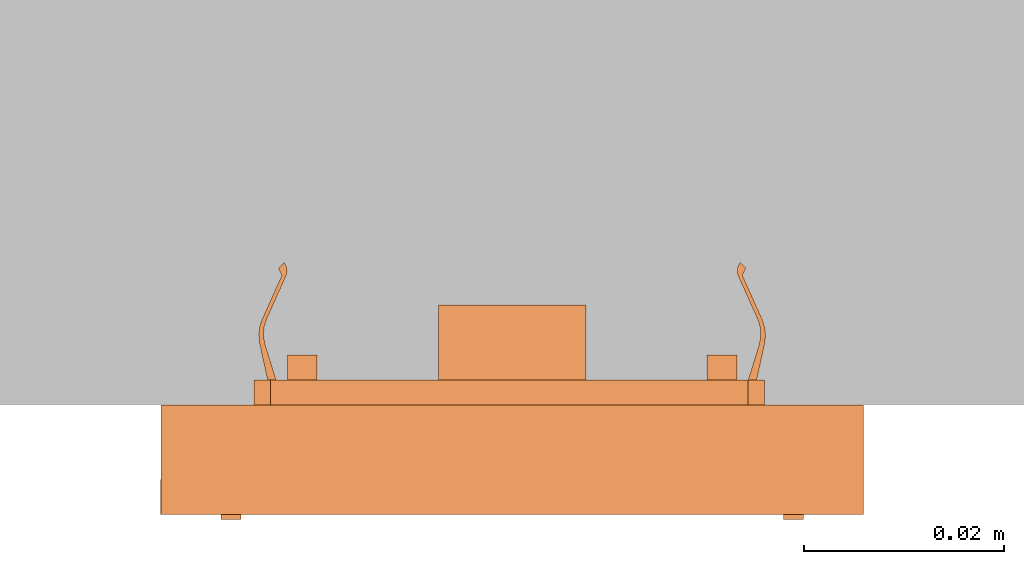
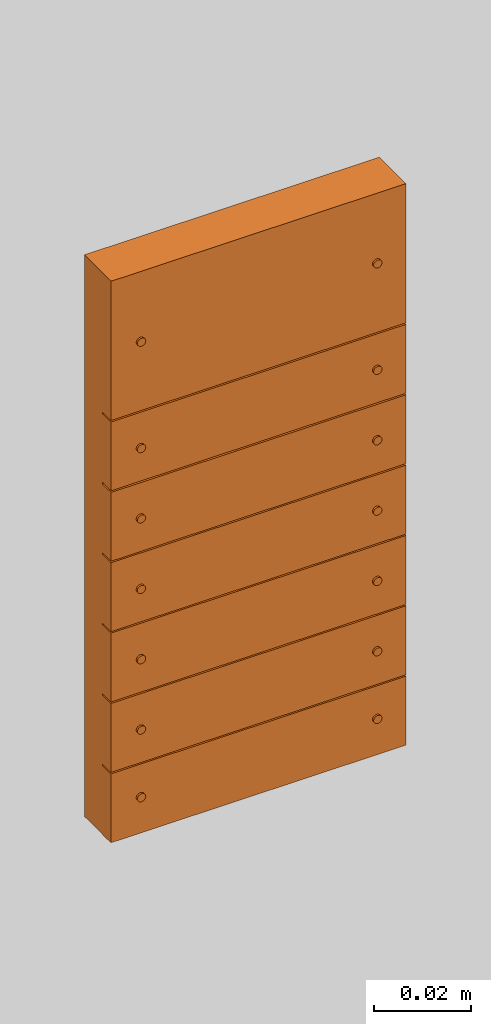
# One storey, part 2 of 2: 1 proxy.
"""IFC2X3 building model written with IfcOpenShell, lengths in metres."""

import ifcopenshell
import ifcopenshell.guid

model = None  # the IFC model being written
_history = None  # IfcOwnerHistory: only IFC2X3 demands one
_inside = {}  # id of a spatial element -> (the spatial element, [elements in it])
_under = {}  # id of a project, library or spatial element -> (it, [spatial elements below it])
_declared = {}  # id of a project -> (the project, [libraries it declares])
_typed = {}  # id of a type object -> (the type object, [elements of that type])
_made_of = {}  # id of a material, layer set ... -> (it, [elements and type objects made of it])


def new_model(schema):
    """Start an empty IFC model of exactly this schema.

    Asked for "IFC4X3", IfcOpenShell would pick the latest addendum, in which some entities
    have other attributes; the version numbers below select the first issue.
    IFC2X3 requires an IfcOwnerHistory on every rooted entity: one is made here for all.
    """
    global model, _history
    if schema == "IFC4X3":
        model = ifcopenshell.file(schema_version=(4, 3, 0, 0))
    else:
        model = ifcopenshell.file(schema=schema)
    _inside.clear()
    _under.clear()
    _declared.clear()
    _typed.clear()
    _made_of.clear()
    _history = None
    if model.schema == "IFC2X3":
        org = make("IfcOrganization", Name="unknown")
        user = make(
            "IfcPersonAndOrganization",
            ThePerson=make("IfcPerson", FamilyName="unknown"),
            TheOrganization=org,
        )
        app = make(
            "IfcApplication",
            ApplicationDeveloper=org,
            Version="unknown",
            ApplicationFullName="unknown",
            ApplicationIdentifier="unknown",
        )
        _history = make(
            "IfcOwnerHistory",
            OwningUser=user,
            OwningApplication=app,
            ChangeAction="ADDED",
            CreationDate=0,
        )
    return model


def make(cls, **values):
    """One entity of the class cls with the attributes given. An attribute that is None is left unset."""
    return model.create_entity(
        cls, **{name: value for name, value in values.items() if value is not None}
    )


def entity(cls, *values):
    """Any entity or typed value of the class cls, its attributes in the order of the schema. None: left unset."""
    e = model.create_entity(cls)
    for i, value in enumerate(values):
        if value is not None:
            e[i] = value
    return e


def rooted(cls, **values):
    """An entity with a GlobalId (a new one), such as an element, a storey or a relation."""
    return make(cls, GlobalId=ifcopenshell.guid.new(), OwnerHistory=_history, **values)


def si_unit(unit_type, name, prefix=None):
    """IfcSIUnit, for example si_unit("LENGTHUNIT", "METRE", prefix="MILLI")."""
    return make("IfcSIUnit", UnitType=unit_type, Prefix=prefix, Name=name)


def converted_unit(unit_type, name, factor, base, dimensions=None, offset=None):
    """IfcConversionBasedUnit, such as the inch: factor (a typed value) times the base unit."""
    return make(
        "IfcConversionBasedUnit"
        if offset is None
        else "IfcConversionBasedUnitWithOffset",
        ConversionOffset=offset,
        Dimensions=None
        if dimensions is None
        else entity("IfcDimensionalExponents", *dimensions),
        UnitType=unit_type,
        Name=name,
        ConversionFactor=make(
            "IfcMeasureWithUnit", ValueComponent=factor, UnitComponent=base
        ),
    )


def derived_unit(unit_type, elements):
    """IfcDerivedUnit: a product of units, each with its exponent."""
    return make(
        "IfcDerivedUnit",
        Elements=[
            make("IfcDerivedUnitElement", Unit=unit, Exponent=power)
            for unit, power in elements
        ],
        UnitType=unit_type,
    )


def assignment(units):
    """IfcUnitAssignment: the units of a project."""
    return None if units is None else make("IfcUnitAssignment", Units=units)


def point(xyz):
    """IfcCartesianPoint."""
    return None if xyz is None else make("IfcCartesianPoint", Coordinates=xyz)


def direction(xyz):
    """IfcDirection."""
    return None if xyz is None else make("IfcDirection", DirectionRatios=xyz)


def frame(location, z_axis=None, x_axis=None):
    """IfcAxis2Placement3D, a coordinate frame: its origin and axes. An axis left out is left unset."""
    return make(
        "IfcAxis2Placement3D",
        Location=point(location),
        Axis=direction(z_axis),
        RefDirection=direction(x_axis),
    )


def frame_2d(location, x_axis=None):
    """IfcAxis2Placement2D, a coordinate frame in the plane: its origin and x axis."""
    return make(
        "IfcAxis2Placement2D", Location=point(location), RefDirection=direction(x_axis)
    )


def origin():
    """The frame at (0, 0, 0) with its axes left unset."""
    return frame((0.0, 0.0, 0.0))


def origin_2d_with_axis():
    """The frame at (0, 0) in the plane with the x axis (1, 0) written out."""
    return frame_2d((0.0, 0.0), x_axis=(1.0, 0.0))


def place(relative_to, where):
    """IfcLocalPlacement: puts the frame where relative to a parent placement (None: the world)."""
    return make(
        "IfcLocalPlacement", PlacementRelTo=relative_to, RelativePlacement=where
    )


def context(
    kind, dimensions, precision=None, world=None, true_north=None, identifier=None
):
    """IfcGeometricRepresentationContext, for example the 3D "Model" context."""
    return make(
        "IfcGeometricRepresentationContext",
        ContextIdentifier=identifier,
        ContextType=kind,
        CoordinateSpaceDimension=dimensions,
        Precision=precision,
        WorldCoordinateSystem=world,
        TrueNorth=true_north,
    )


def subcontext(parent, identifier, kind, view, scale=None):
    """IfcGeometricRepresentationSubContext, for example "Body" below "Model"."""
    return make(
        "IfcGeometricRepresentationSubContext",
        ContextIdentifier=identifier,
        ContextType=kind,
        ParentContext=parent,
        TargetScale=scale,
        TargetView=view,
    )


def project(units=None, contexts=None):
    """IfcProject with its units and contexts."""
    return rooted(
        "IfcProject",
        Name="project",
        RepresentationContexts=contexts,
        UnitsInContext=assignment(units),
    )


def spatial(cls, under=None, at=None, **own):
    """A site, building, storey or space (cls), placed at a placement, below another one or the project."""
    s = rooted(cls, ObjectPlacement=at, **own)
    if under is not None:
        _under.setdefault(under.id(), (under, []))[1].append(s)
    return s


def polyline(points):
    """IfcPolyline through the points."""
    return make("IfcPolyline", Points=[point(p) for p in points])


def circle_curve(where, radius):
    """IfcCircle in the frame where."""
    return make("IfcCircle", Position=where, Radius=radius)


def parameter(value):
    """IfcParameterValue: where a trimmed curve begins or ends, as a parameter of its basis curve."""
    return model.create_entity("IfcParameterValue", value)


def trimmed(basis, trim1, trim2, sense, master):
    """IfcTrimmedCurve: the piece of a basis curve between two trims."""
    return make(
        "IfcTrimmedCurve",
        BasisCurve=basis,
        Trim1=trim1,
        Trim2=trim2,
        SenseAgreement=sense,
        MasterRepresentation=master,
    )


def segment(curve, same_sense, transition):
    """IfcCompositeCurveSegment."""
    return make(
        "IfcCompositeCurveSegment",
        Transition=transition,
        SameSense=same_sense,
        ParentCurve=curve,
    )


def composite_curve(segments, self_intersect=None):
    """IfcCompositeCurve: segments joined end to end."""
    return make("IfcCompositeCurve", Segments=segments, SelfIntersect=self_intersect)


def profile(cls, at=None, kind="AREA", **sizes):
    """A parametric profile (cls). Its sizes go by their IFC names, for example OverallWidth=200.0."""
    return make(cls, ProfileType=kind, Position=at, **sizes)


def rectangle(**sizes):
    """IfcRectangleProfileDef."""
    return profile("IfcRectangleProfileDef", **sizes)


def circle(**sizes):
    """IfcCircleProfileDef."""
    return profile("IfcCircleProfileDef", **sizes)


def outline(outer, holes=None, kind="AREA"):
    """IfcArbitraryClosedProfileDef: a profile drawn as a closed curve; with holes, ...WithVoids."""
    if holes is None:
        return make("IfcArbitraryClosedProfileDef", ProfileType=kind, OuterCurve=outer)
    return make(
        "IfcArbitraryProfileDefWithVoids",
        ProfileType=kind,
        OuterCurve=outer,
        InnerCurves=holes,
    )


def extrude(swept, where, along, depth):
    """IfcExtrudedAreaSolid: the profile swept, set in the frame where, extruded along a direction by depth."""
    return make(
        "IfcExtrudedAreaSolid",
        SweptArea=swept,
        Position=where,
        ExtrudedDirection=direction(along),
        Depth=depth,
    )


def shape(context_of_items, identifier, shape_type, items):
    """IfcShapeRepresentation: the items that make up one representation, for example the "Body"."""
    return make(
        "IfcShapeRepresentation",
        ContextOfItems=context_of_items,
        RepresentationIdentifier=identifier,
        RepresentationType=shape_type,
        Items=items,
    )


def source(mapping_origin, context_of_items, identifier, shape_type, items):
    """IfcRepresentationMap: a shape defined once, which mapped items show again and again."""
    return make(
        "IfcRepresentationMap",
        MappingOrigin=mapping_origin,
        MappedRepresentation=shape(context_of_items, identifier, shape_type, items),
    )


def transform(
    local_origin,
    x_axis=None,
    y_axis=None,
    z_axis=None,
    scale=None,
    scale2=None,
    scale3=None,
    uniform=True,
):
    """IfcCartesianTransformationOperator3D, or its non-uniform kind. x_axis, y_axis, z_axis: its Axis1, 2, 3."""
    if uniform:
        return make(
            "IfcCartesianTransformationOperator3D",
            Axis1=direction(x_axis),
            Axis2=direction(y_axis),
            LocalOrigin=point(local_origin),
            Scale=scale,
            Axis3=direction(z_axis),
        )
    return make(
        "IfcCartesianTransformationOperator3DnonUniform",
        Axis1=direction(x_axis),
        Axis2=direction(y_axis),
        LocalOrigin=point(local_origin),
        Scale=scale,
        Axis3=direction(z_axis),
        Scale2=scale2,
        Scale3=scale3,
    )


def mapped(mapping_source, mapping_target):
    """IfcMappedItem: shows the shape of a source again, moved by a transform."""
    return make(
        "IfcMappedItem", MappingSource=mapping_source, MappingTarget=mapping_target
    )


def made_of(thing, what):
    """Note that an element or type object is made of a material, layer set ...; save() writes the relation."""
    if what is not None:
        _made_of.setdefault(what.id(), (what, []))[1].append(thing)
    return thing


def type_object(cls, material=None, **own):
    """A type object (cls), such as IfcWallType, which elements share."""
    return made_of(rooted(cls, **own), material)


def type_shapes(of_type, sources):
    """Give a type object the sources (RepresentationMaps) that its elements show as mapped items."""
    of_type.RepresentationMaps = sources


def element(
    cls,
    number,
    at=None,
    inside=None,
    cuts=None,
    type_object=None,
    material=None,
    context=None,
    identifier="Body",
    shape_type=None,
    held_by="IfcProductDefinitionShape",
    body=None,
    shapes=None,
    **own,
):
    """One element of the class cls, such as IfcWall. Its Tag is "e" and its number.

    at: its placement. inside: the storey or other place that contains it. cuts: it is an
    opening in that element (IfcRelVoidsElement). A single representation is given by context,
    identifier, shape_type and body (its items); several are given by shapes. held_by: the class
    of the entity that holds the representations. save() writes the other relations.
    """
    e = rooted(cls, Tag="e%d" % number, ObjectPlacement=at, **own)
    if body is not None:
        shapes = [shape(context, identifier, shape_type, body)]
    if shapes is not None:
        e.Representation = make(held_by, Representations=shapes)
    if inside is not None:
        _inside.setdefault(inside.id(), (inside, []))[1].append(e)
    if cuts is not None:
        rooted(
            "IfcRelVoidsElement", RelatingBuildingElement=cuts, RelatedOpeningElement=e
        )
    if type_object is not None:
        _typed.setdefault(type_object.id(), (type_object, []))[1].append(e)
    return made_of(e, material)


def aggregate(whole, parts):
    """IfcRelAggregates: a whole, such as a stair, and the parts it consists of."""
    return rooted("IfcRelAggregates", RelatingObject=whole, RelatedObjects=parts)


def save(model, path):
    """Write the relations noted so far, then the file.

    IfcRelAggregates (storeys below a building ...), IfcRelContainedInSpatialStructure (elements
    in a storey), IfcRelDefinesByType, IfcRelAssociatesMaterial and IfcRelDeclares: one each for
    every whole, place, type object, material and project.
    """
    for whole, parts in _under.values():
        aggregate(whole, parts)
    for where, things in _inside.values():
        rooted(
            "IfcRelContainedInSpatialStructure",
            RelatedElements=things,
            RelatingStructure=where,
        )
    for kind, things in _typed.values():
        rooted("IfcRelDefinesByType", RelatedObjects=things, RelatingType=kind)
    for what, things in _made_of.values():
        rooted("IfcRelAssociatesMaterial", RelatedObjects=things, RelatingMaterial=what)
    for by, libraries in _declared.values():
        rooted("IfcRelDeclares", RelatingContext=by, RelatedDefinitions=libraries)
    model.write(path)


model = new_model("IFC2X3")

# Units and contexts
model_context = context("Model", 3, precision=1e-05, world=origin(), true_north=direction((6.12303176911189e-17, 1.0)))
body_context = subcontext(model_context, "Body", "Model", "MODEL_VIEW")
ifc_project = project(units=[si_unit("LENGTHUNIT", "METRE"), si_unit("AREAUNIT", "SQUARE_METRE"), si_unit("VOLUMEUNIT", "CUBIC_METRE"), converted_unit("PLANEANGLEUNIT", "DEGREE", entity("IfcRatioMeasure", 0.0174532925199433), si_unit("PLANEANGLEUNIT", "RADIAN"), dimensions=[0, 0, 0, 0, 0, 0, 0]), si_unit("MASSUNIT", "GRAM", prefix="KILO"), si_unit("TIMEUNIT", "SECOND"), si_unit("FREQUENCYUNIT", "HERTZ"), si_unit("THERMODYNAMICTEMPERATUREUNIT", "DEGREE_CELSIUS"), derived_unit("THERMALTRANSMITTANCEUNIT", [(si_unit("MASSUNIT", "GRAM", prefix="KILO"), 1), (si_unit("THERMODYNAMICTEMPERATUREUNIT", "KELVIN"), -1), (si_unit("TIMEUNIT", "SECOND"), -3)]), derived_unit("VOLUMETRICFLOWRATEUNIT", [(si_unit("LENGTHUNIT", "METRE"), 3), (si_unit("TIMEUNIT", "SECOND"), -1)]), si_unit("ELECTRICCURRENTUNIT", "AMPERE"), si_unit("ELECTRICVOLTAGEUNIT", "VOLT"), si_unit("POWERUNIT", "WATT"), si_unit("FORCEUNIT", "NEWTON", prefix="KILO"), si_unit("ILLUMINANCEUNIT", "LUX"), si_unit("LUMINOUSFLUXUNIT", "LUMEN"), si_unit("LUMINOUSINTENSITYUNIT", "CANDELA"), derived_unit("USERDEFINED", [(si_unit("MASSUNIT", "GRAM", prefix="KILO"), -1), (si_unit("LENGTHUNIT", "METRE"), -2), (si_unit("TIMEUNIT", "SECOND"), 3), (si_unit("LUMINOUSFLUXUNIT", "LUMEN"), 1)]), derived_unit("LINEARVELOCITYUNIT", [(si_unit("LENGTHUNIT", "METRE"), 1), (si_unit("TIMEUNIT", "SECOND"), -1)]), si_unit("PRESSUREUNIT", "PASCAL"), derived_unit("USERDEFINED", [(si_unit("LENGTHUNIT", "METRE"), -2), (si_unit("MASSUNIT", "GRAM", prefix="KILO"), 1), (si_unit("TIMEUNIT", "SECOND"), -2)])], contexts=[model_context])

# Site, building, storey
site_placement = place(None, origin())
site = spatial("IfcSite", under=ifc_project, at=site_placement, CompositionType="ELEMENT")
building_placement = place(site_placement, origin())
building = spatial("IfcBuilding", under=site, at=building_placement, CompositionType="ELEMENT")
storey_placement = place(building_placement, origin())
storey = spatial("IfcBuildingStorey", under=building, at=storey_placement, Name="Ebene 0", CompositionType="ELEMENT", Elevation=0.0)

# Proxy
building_element_proxy_type = type_object("IfcBuildingElementProxyType", Name="KNX 3 Plus 6f (2+4)", PredefinedType="NOTDEFINED")
shared_shape = source(origin(), body_context, "Body", "SweptSolid", [
    extrude(outline(composite_curve([segment(polyline([(0.000467124920745134, -0.0238772156111111), (0.0193443469207452, -0.0238772156111111)]), True, "CONTINUOUS"), segment(trimmed(circle_curve(frame_2d((0.0193443469207451, -0.0188772156111111), x_axis=(-1.0, 0.0)), 0.005), [parameter(90.0000000000001)], [parameter(180.0)], True, "PARAMETER"), True, "CONTINUOUS"), segment(polyline([(0.0243443469207451, -0.0188772156111111), (0.0243443469207451, -0.00697722161111111)]), True, "CONTINUOUS"), segment(polyline([(0.0243443469207451, -0.00697722161111111), (0.0259943469207451, -0.00697722161111111)]), True, "CONTINUOUS"), segment(polyline([(0.0259943469207451, -0.00697722161111111), (0.0259943469207451, 0.0069772233888889)]), True, "CONTINUOUS"), segment(polyline([(0.0259943469207451, 0.0069772233888889), (0.0243443469207451, 0.0069772233888889)]), True, "CONTINUOUS"), segment(polyline([(0.0243443469207451, 0.0069772233888889), (0.0243443469207451, 0.0188772173888889)]), True, "CONTINUOUS"), segment(trimmed(circle_curve(frame_2d((0.0193443469207451, 0.0188772173888889), x_axis=(-1.0, 0.0)), 0.005), [parameter(180.0)], [parameter(269.999999999999)], True, "PARAMETER"), True, "CONTINUOUS"), segment(polyline([(0.0193443469207451, 0.0238772173888889), (-0.00794112365266727, 0.0238772173888889)]), True, "CONTINUOUS"), segment(polyline([(-0.00794112365266727, 0.0238772173888889), (-0.0184100970792549, 0.0238772173888889)]), True, "CONTINUOUS"), segment(trimmed(circle_curve(frame_2d((-0.0184100970792549, 0.0188772173888889), x_axis=(-1.0, 0.0)), 0.005), [parameter(270.0)], [parameter(360.0)], True, "PARAMETER"), True, "CONTINUOUS"), segment(polyline([(-0.0234100970792549, 0.0188772173888889), (-0.0234100970792549, 0.0069772233888889)]), True, "CONTINUOUS"), segment(polyline([(-0.0234100970792549, 0.0069772233888889), (-0.0250600970792549, 0.0069772233888889)]), True, "CONTINUOUS"), segment(polyline([(-0.0250600970792549, 0.0069772233888889), (-0.0250600970792549, -0.00697722161111111)]), True, "CONTINUOUS"), segment(polyline([(-0.0250600970792549, -0.00697722161111111), (-0.0234100970792549, -0.00697722161111111)]), True, "CONTINUOUS"), segment(polyline([(-0.0234100970792549, -0.00697722161111111), (-0.0234100970792549, -0.0188772236111111)]), True, "CONTINUOUS"), segment(trimmed(circle_curve(frame_2d((-0.0184100970792549, -0.0188772236111111), x_axis=(-1.0, 0.0)), 0.005), [parameter(0.0)], [parameter(90.0000000000001)], True, "PARAMETER"), True, "CONTINUOUS"), segment(polyline([(-0.0184100970792548, -0.0238772236111111), (0.000467124920745136, -0.0238772236111111)]), True, "CONTINUOUS")], self_intersect=False)), frame((0.000176586434071463, -0.0709999951111364, -0.00250000000000187), z_axis=(0.0, 0.0, 1.0), x_axis=(-1.0, 0.0, 0.0)), (0.0, 0.0, 1.0), 0.0025),
    extrude(circle(Radius=0.001, at=origin_2d_with_axis()), frame((0.0281503279999938, -0.0969685375000254, 0.0109999999999981), z_axis=(0.0, 0.0, 1.0), x_axis=(-1.0, 0.0, 0.0)), (0.0, 0.0, 1.0), 0.000500000000000028),
    extrude(circle(Radius=0.001, at=origin_2d_with_axis()), frame((-0.0281503279999813, -0.0969685375000254, 0.0109999999999981)), (0.0, 0.0, 1.0), 0.000500000000000028),
    extrude(circle(Radius=0.001, at=origin_2d_with_axis()), frame((0.0281503279999938, -0.0799535355000252, 0.0109999999999981), z_axis=(0.0, 0.0, 1.0), x_axis=(-1.0, 0.0, 0.0)), (0.0, 0.0, 1.0), 0.000500000000000028),
    extrude(circle(Radius=0.001, at=origin_2d_with_axis()), frame((-0.0281503279999813, -0.0799535355000252, 0.0109999999999981)), (0.0, 0.0, 1.0), 0.000500000000000028),
    extrude(circle(Radius=0.001, at=origin_2d_with_axis()), frame((0.0281503279999938, -0.0622244115000253, 0.0109999999999981), z_axis=(0.0, 0.0, 1.0), x_axis=(-1.0, 0.0, 0.0)), (0.0, 0.0, 1.0), 0.000500000000000028),
    extrude(circle(Radius=0.001, at=origin_2d_with_axis()), frame((-0.0281503279999813, -0.0622244115000253, 0.0109999999999981)), (0.0, 0.0, 1.0), 0.000500000000000028),
    extrude(circle(Radius=0.001, at=origin_2d_with_axis()), frame((0.0281503279999938, -0.0445001955000252, 0.0109999999999981), z_axis=(0.0, 0.0, 1.0), x_axis=(-1.0, 0.0, 0.0)), (0.0, 0.0, 1.0), 0.000500000000000028),
    extrude(circle(Radius=0.001, at=origin_2d_with_axis()), frame((-0.0281503279999813, -0.0445001955000252, 0.0109999999999981)), (0.0, 0.0, 1.0), 0.000500000000000028),
    extrude(circle(Radius=0.001, at=frame_2d((0.0, -4.22994972382185e-18), x_axis=(1.0, 0.0))), frame((0.0281503279999938, -0.0267710735000253, 0.0109999999999981), z_axis=(0.0, 0.0, 1.0), x_axis=(-1.0, 0.0, 0.0)), (0.0, 0.0, 1.0), 0.000500000000000028),
    extrude(circle(Radius=0.001, at=frame_2d((0.0, -4.22994972382185e-18), x_axis=(1.0, 0.0))), frame((-0.0281503279999813, -0.0267710735000253, 0.0109999999999981)), (0.0, 0.0, 1.0), 0.000500000000000028),
    extrude(circle(Radius=0.001, at=frame_2d((0.0, -2.11497486191092e-18), x_axis=(1.0, 0.0))), frame((0.0281503279999938, -0.00902937150002529, 0.0109999999999981), z_axis=(0.0, 0.0, 1.0), x_axis=(-1.0, 0.0, 0.0)), (0.0, 0.0, 1.0), 0.000500000000000028),
    extrude(circle(Radius=0.001, at=frame_2d((0.0, -2.11497486191092e-18), x_axis=(1.0, 0.0))), frame((-0.0281503279999813, -0.00902937150002528, 0.0109999999999981)), (0.0, 0.0, 1.0), 0.000500000000000028),
    extrude(circle(Radius=0.001, at=frame_2d((0.0, -2.11497486191092e-18), x_axis=(1.0, 0.0))), frame((0.0281503279999938, 0.0177710734999747, 0.0109999999999981), z_axis=(0.0, 0.0, 1.0), x_axis=(-1.0, 0.0, 0.0)), (0.0, 0.0, 1.0), 0.000500000000000028),
    extrude(circle(Radius=0.001, at=frame_2d((0.0, -2.11497486191092e-18), x_axis=(1.0, 0.0))), frame((-0.0281503279999812, 0.0177710734999747, 0.0109999999999981)), (0.0, 0.0, 1.0), 0.000500000000000028),
    extrude(outline(polyline([(-0.00737665776090717, -0.00321845649999999), (0.00738192423909283, -0.00321845649999999), (0.00738192423909283, 0.00284013749999998), (0.00654480379664712, 0.00284013749999998), (0.00654480379664711, -0.00245988050000001), (-0.00655007027483279, -0.00245988050000001), (-0.00655007027483277, 0.00283819950000002), (-0.00737665776090717, 0.00283819950000002), (-0.00737665776090717, -0.00321845649999999)])), frame((2.6332391116218e-06, -0.0187020095000253, -0.0100000000000019), z_axis=(0.0, 0.0, 1.0), x_axis=(-1.0, 0.0, 0.0)), (0.0, 0.0, 1.0), 0.0075),
    extrude(outline(composite_curve([segment(polyline([(0.000467124920745132, -0.0238772156111111), (0.0193443469207452, -0.0238772156111111)]), True, "CONTINUOUS"), segment(trimmed(circle_curve(frame_2d((0.0193443469207451, -0.0188772156111111), x_axis=(-1.0, 0.0)), 0.005), [parameter(90.0000000000001)], [parameter(180.0)], True, "PARAMETER"), True, "CONTINUOUS"), segment(polyline([(0.0243443469207451, -0.0188772156111111), (0.0243443469207451, -0.0069772216111111)]), True, "CONTINUOUS"), segment(polyline([(0.0243443469207451, -0.0069772216111111), (0.0259943469207451, -0.0069772216111111)]), True, "CONTINUOUS"), segment(polyline([(0.0259943469207451, -0.0069772216111111), (0.0259943469207451, 0.00697722338888889)]), True, "CONTINUOUS"), segment(polyline([(0.0259943469207451, 0.00697722338888889), (0.0243443469207451, 0.00697722338888889)]), True, "CONTINUOUS"), segment(polyline([(0.0243443469207451, 0.00697722338888889), (0.0243443469207451, 0.0188772173888889)]), True, "CONTINUOUS"), segment(trimmed(circle_curve(frame_2d((0.0193443469207451, 0.0188772173888889), x_axis=(-1.0, 0.0)), 0.005), [parameter(180.0)], [parameter(269.999999999999)], True, "PARAMETER"), True, "CONTINUOUS"), segment(polyline([(0.0193443469207451, 0.0238772173888889), (-0.00794112365266727, 0.0238772173888889)]), True, "CONTINUOUS"), segment(polyline([(-0.00794112365266727, 0.0238772173888889), (-0.0184100970792549, 0.0238772173888889)]), True, "CONTINUOUS"), segment(trimmed(circle_curve(frame_2d((-0.0184100970792549, 0.0188772173888889), x_axis=(-1.0, 0.0)), 0.005), [parameter(270.0)], [parameter(360.0)], True, "PARAMETER"), True, "CONTINUOUS"), segment(polyline([(-0.0234100970792549, 0.0188772173888889), (-0.0234100970792549, 0.00697722338888889)]), True, "CONTINUOUS"), segment(polyline([(-0.0234100970792549, 0.00697722338888889), (-0.0250600970792549, 0.00697722338888889)]), True, "CONTINUOUS"), segment(polyline([(-0.0250600970792549, 0.00697722338888889), (-0.0250600970792549, -0.0069772216111111)]), True, "CONTINUOUS"), segment(polyline([(-0.0250600970792549, -0.0069772216111111), (-0.0234100970792549, -0.0069772216111111)]), True, "CONTINUOUS"), segment(polyline([(-0.0234100970792549, -0.0069772216111111), (-0.0234100970792549, -0.0188772236111111)]), True, "CONTINUOUS"), segment(trimmed(circle_curve(frame_2d((-0.0184100970792549, -0.0188772236111111), x_axis=(-1.0, 0.0)), 0.005), [parameter(0.0)], [parameter(90.0000000000001)], True, "PARAMETER"), True, "CONTINUOUS"), segment(polyline([(-0.0184100970792548, -0.0238772236111111), (0.000467124920745134, -0.0238772236111111)]), True, "CONTINUOUS")], self_intersect=False)), frame((0.000176586434071575, 4.88886360231292e-09, -0.00250000000000187), z_axis=(0.0, 0.0, 1.0), x_axis=(-1.0, 0.0, 0.0)), (0.0, 0.0, 1.0), 0.0025),
    extrude(rectangle(XDim=0.070301005, YDim=0.017347165, at=origin_2d_with_axis()), frame((0.0, -0.00885578900002528, 0.0074999999999981), z_axis=(0.0, 0.0, 1.0), x_axis=(-1.0, 0.0, 0.0)), (0.0, 0.0, 1.0), 0.0035),
    extrude(rectangle(XDim=0.070300656, YDim=0.035073517, at=origin_2d_with_axis()), frame((0.0, 0.0177343149999747, 0.0074999999999981), z_axis=(0.0, 0.0, 1.0), x_axis=(-1.0, 0.0, 0.0)), (0.0, 0.0, 1.0), 0.0035),
    extrude(rectangle(XDim=0.070301005, YDim=0.017347165, at=origin_2d_with_axis()), frame((0.0, -0.0265974910000253, 0.0074999999999981), z_axis=(0.0, 0.0, 1.0), x_axis=(-1.0, 0.0, 0.0)), (0.0, 0.0, 1.0), 0.0035),
    extrude(rectangle(XDim=0.017372064, YDim=0.070325902, at=origin_2d_with_axis()), frame((-1.26229999812224e-05, -0.0443216665000252, 0.0074999999999981), z_axis=(0.0, 0.0, 1.0), x_axis=(0.0, 1.0, 0.0)), (0.0, 0.0, 1.0), 0.0035),
    extrude(rectangle(XDim=0.017372064, YDim=0.070325902, at=origin_2d_with_axis()), frame((-1.26229999812224e-05, -0.0620483355000252, 0.0074999999999981), z_axis=(0.0, 0.0, 1.0), x_axis=(0.0, 1.0, 0.0)), (0.0, 0.0, 1.0), 0.0035),
    extrude(rectangle(XDim=0.017372063, YDim=0.070325902, at=frame_2d((0.0, 3.46944695195361e-18), x_axis=(1.0, 0.0))), frame((-1.26229999812224e-05, -0.0797750050000253, 0.0074999999999981), z_axis=(0.0, 0.0, 1.0), x_axis=(0.0, 1.0, 0.0)), (0.0, 0.0, 1.0), 0.0035),
    extrude(rectangle(XDim=0.017372064, YDim=0.070325902, at=origin_2d_with_axis()), frame((-1.26229999812224e-05, -0.0975016895000253, 0.0074999999999981), z_axis=(0.0, 0.0, 1.0), x_axis=(0.0, 1.0, 0.0)), (0.0, 0.0, 1.0), 0.0035),
    extrude(outline(composite_curve([segment(polyline([(0.000472292951185432, 0.000420953599132343), (0.00416321367313665, 0.000420953599132342)]), True, "CONTINUOUS"), segment(trimmed(circle_curve(frame_2d((0.00416321367313664, 0.00181721258376423), x_axis=(0.409756024020064, -0.912195154985636)), 0.00139625898463189), [parameter(335.810490465145)], [parameter(36.8186761544855)], True, "PARAMETER"), True, "CONTINUOUS"), segment(polyline([(0.00538450599455828, 0.00114046727140381), (0.00463474768077748, 0.00142543083253439)]), True, "CONTINUOUS"), segment(polyline([(0.00463474768077748, 0.00142543083253439), (0.00411278343040261, 0.000820953215477426)]), True, "CONTINUOUS"), segment(polyline([(0.00411278343040261, 0.000820953215477426), (-0.000727608155903879, 0.000820954557792182)]), True, "CONTINUOUS"), segment(trimmed(circle_curve(frame_2d((-0.000727609215800362, -0.00300103577571181), x_axis=(0.409756024020064, -0.912195154985636)), 0.00382199033350414), [parameter(155.810474576148)], [parameter(192.350109036284)], True, "PARAMETER"), True, "CONTINUOUS"), segment(polyline([(-0.00300314005330673, 6.97246377618049e-05), (-0.00600132943591547, -0.00215202876470991)]), True, "CONTINUOUS"), segment(polyline([(-0.00600132943591547, -0.00215202876470991), (-0.00565606856887739, -0.00292064538449353)]), True, "CONTINUOUS"), segment(polyline([(-0.00565606856887739, -0.00292064538449353), (-0.00286756758826518, -0.000467717865723011)]), True, "CONTINUOUS"), segment(trimmed(circle_curve(frame_2d((-0.000511832474027628, -0.00314573000666332), x_axis=(0.409756024020064, -0.912195154985636)), 0.00356668430835636), [parameter(155.810449562011)], [parameter(197.147226297286)], True, "PARAMETER"), False, "CONTINUOUS"), segment(polyline([(-0.000511829927791779, 0.000420954301692136), (0.000472292951185432, 0.000420953599132343)]), True, "CONTINUOUS")], self_intersect=False)), frame((-0.0239747857969799, 0.00449999999999145, -0.00885619038512098), z_axis=(0.0, 1.0, 0.0), x_axis=(0.409756024020064, 0.0, -0.912195154985636)), (0.0, 0.0, 1.0), 0.003),
    extrude(outline(composite_curve([segment(polyline([(-0.000472292650668896, -0.000420953936299523), (-0.00416321337261916, -0.000420956571227145)]), True, "CONTINUOUS"), segment(trimmed(circle_curve(frame_2d((-0.0041632123758377, -0.00181721555585867), x_axis=(-0.409756675230966, 0.912194862462876)), 0.00139625898463189), [parameter(335.810490465146)], [parameter(36.8186761544859)], True, "PARAMETER"), True, "CONTINUOUS"), segment(polyline([(-0.00538450518038372, -0.00114047111537216), (-0.00463474666316922, -0.00142543414125442)]), True, "CONTINUOUS"), segment(polyline([(-0.00463474666316922, -0.00142543414125442), (-0.00411278284432766, -0.000820956151570249)]), True, "CONTINUOUS"), segment(polyline([(-0.00411278284432766, -0.000820956151570249), (0.000727608741978554, -0.000820954038356592)]), True, "CONTINUOUS"), segment(trimmed(circle_curve(frame_2d((0.000727607073377565, 0.00300103629514719), x_axis=(-0.409756675230966, 0.912194862462876)), 0.00382199033350414), [parameter(155.810474576148)], [parameter(192.350109036284)], True, "PARAMETER"), True, "CONTINUOUS"), segment(polyline([(0.003003140103082, -6.972249383695e-05), (0.00600132789959267, 0.00215203304902479)]), True, "CONTINUOUS"), segment(polyline([(0.00600132789959267, 0.00215203304902479), (0.00565606648384359, 0.00292064942232842)]), True, "CONTINUOUS"), segment(polyline([(0.00565606648384359, 0.00292064942232842), (0.00286756725436329, 0.000467719912863318)]), True, "CONTINUOUS"), segment(trimmed(circle_curve(frame_2d((0.000511830228308488, 0.00314573037205685), x_axis=(-0.409756675230966, 0.912194862462876)), 0.00356668430835636), [parameter(155.810449562011)], [parameter(197.147226297286)], True, "PARAMETER"), False, "CONTINUOUS"), segment(polyline([(0.00051183022830858, -0.000420953936299522), (-0.000472292650668896, -0.000420953936299523)]), True, "CONTINUOUS")], self_intersect=False)), frame((0.0239747857969922, 0.00449999999999145, -0.00885619038512148), z_axis=(0.0, -1.0, 0.0), x_axis=(0.409756675230985, 0.0, 0.912194862462867)), (0.0, 0.0, -1.0), 0.003),
    extrude(outline(composite_curve([segment(polyline([(-0.000472292650668898, -0.00042095393629952), (-0.00416321337261917, -0.000420956571227123)]), True, "CONTINUOUS"), segment(trimmed(circle_curve(frame_2d((-0.00416321237583771, -0.00181721555585865), x_axis=(-0.409756675230961, 0.912194862462878)), 0.00139625898463189), [parameter(335.810490465145)], [parameter(36.8186761544855)], True, "PARAMETER"), True, "CONTINUOUS"), segment(polyline([(-0.00538450518038373, -0.00114047111537213), (-0.00463474666316922, -0.00142543414125439)]), True, "CONTINUOUS"), segment(polyline([(-0.00463474666316922, -0.00142543414125439), (-0.00411278284432766, -0.000820956151570226)]), True, "CONTINUOUS"), segment(polyline([(-0.00411278284432766, -0.000820956151570226), (0.000727608741978553, -0.000820954038356594)]), True, "CONTINUOUS"), segment(trimmed(circle_curve(frame_2d((0.00072760707337758, 0.00300103629514718), x_axis=(-0.409756675230961, 0.912194862462878)), 0.00382199033350414), [parameter(155.810474576148)], [parameter(192.350109036284)], True, "PARAMETER"), True, "CONTINUOUS"), segment(polyline([(0.003003140103082, -6.97224938369658e-05), (0.00600132789959269, 0.00215203304902476)]), True, "CONTINUOUS"), segment(polyline([(0.00600132789959269, 0.00215203304902476), (0.0056560664838436, 0.00292064942232839)]), True, "CONTINUOUS"), segment(polyline([(0.0056560664838436, 0.00292064942232839), (0.00286756725436329, 0.000467719912863301)]), True, "CONTINUOUS"), segment(trimmed(circle_curve(frame_2d((0.000511830228308503, 0.00314573037205685), x_axis=(-0.409756675230961, 0.912194862462878)), 0.00356668430835636), [parameter(155.810449562011)], [parameter(197.147226297286)], True, "PARAMETER"), False, "CONTINUOUS"), segment(polyline([(0.000511830228308568, -0.000420953936299521), (-0.000472292650668898, -0.00042095393629952)]), True, "CONTINUOUS")], self_intersect=False)), frame((0.0239747857969922, -0.00750000000000831, -0.00885619038512152), z_axis=(0.0, -1.0, 0.0), x_axis=(0.40975667523098, 0.0, 0.912194862462869)), (0.0, 0.0, -1.0), 0.003),
    extrude(outline(composite_curve([segment(polyline([(0.000472292951185428, 0.000420953599132341), (0.00416321367313665, 0.000420953599132339)]), True, "CONTINUOUS"), segment(trimmed(circle_curve(frame_2d((0.00416321367313664, 0.00181721258376423), x_axis=(0.409756024020064, -0.912195154985637)), 0.00139625898463189), [parameter(335.810490465146)], [parameter(36.8186761544859)], True, "PARAMETER"), True, "CONTINUOUS"), segment(polyline([(0.00538450599455828, 0.00114046727140381), (0.00463474768077747, 0.00142543083253439)]), True, "CONTINUOUS"), segment(polyline([(0.00463474768077747, 0.00142543083253439), (0.00411278343040261, 0.000820953215477425)]), True, "CONTINUOUS"), segment(polyline([(0.00411278343040261, 0.000820953215477425), (-0.000727608155903882, 0.000820954557792181)]), True, "CONTINUOUS"), segment(trimmed(circle_curve(frame_2d((-0.000727609215800366, -0.00300103577571181), x_axis=(0.409756024020064, -0.912195154985637)), 0.00382199033350414), [parameter(155.810474576148)], [parameter(192.350109036284)], True, "PARAMETER"), True, "CONTINUOUS"), segment(polyline([(-0.00300314005330673, 6.97246377618045e-05), (-0.00600132943591547, -0.00215202876470991)]), True, "CONTINUOUS"), segment(polyline([(-0.00600132943591547, -0.00215202876470991), (-0.00565606856887739, -0.00292064538449353)]), True, "CONTINUOUS"), segment(polyline([(-0.00565606856887739, -0.00292064538449353), (-0.00286756758826519, -0.000467717865723011)]), True, "CONTINUOUS"), segment(trimmed(circle_curve(frame_2d((-0.000511832474027632, -0.00314573000666332), x_axis=(0.409756024020064, -0.912195154985637)), 0.00356668430835636), [parameter(155.810449562011)], [parameter(197.147226297286)], True, "PARAMETER"), False, "CONTINUOUS"), segment(polyline([(-0.000511829927791782, 0.000420954301692135), (0.000472292951185428, 0.000420953599132341)]), True, "CONTINUOUS")], self_intersect=False)), frame((-0.0239747857969799, -0.00750000000000831, -0.00885619038512103), z_axis=(0.0, 1.0, 0.0), x_axis=(0.409756024020064, 0.0, -0.912195154985636)), (0.0, 0.0, 1.0), 0.003),
    extrude(circle(Radius=0.0015, at=frame_2d((0.0, -2.42891644297583e-18), x_axis=(1.0, 0.0))), frame((0.0209999999999937, -7.35170000253137e-05, -0.00500000000000187), z_axis=(0.0, 0.0, 1.0), x_axis=(-1.0, 0.0, 0.0)), (0.0, 0.0, 1.0), 0.0025),
    extrude(circle(Radius=0.0015, at=frame_2d((0.0, -2.42891644297583e-18), x_axis=(1.0, 0.0))), frame((-0.0209999999999812, -7.35170000253089e-05, -0.00500000000000187)), (0.0, 0.0, 1.0), 0.0025),
    extrude(rectangle(XDim=0.141458795, YDim=0.070300656, at=frame_2d((-6.93889390390723e-18, 3.46944695195361e-18), x_axis=(1.0, 0.0))), frame((0.0, -0.0354583240000253, 0.0), z_axis=(0.0, 0.0, 1.0), x_axis=(0.0, -1.0, 0.0)), (0.0, 0.0, 1.0), 0.00749999999999997),
    extrude(rectangle(XDim=0.0130948740714799, YDim=0.00530001800000004, at=frame_2d((0.0, -9.54097911787244e-18), x_axis=(1.0, 0.0))), frame((5.26647820445257e-06, -0.0188921380000253, -0.00350000000000187), z_axis=(0.0, 0.0, 1.0), x_axis=(-1.0, 0.0, 0.0)), (0.0, 0.0, 1.0), 0.001),
])
type_shapes(building_element_proxy_type, [shared_shape])
proxy_placement = place(storey_placement, frame((-7.2192018927039, -2.38240134987377, 1.51080468158631), z_axis=(0.0, -1.0, 0.0), x_axis=(1.0, 0.0, 0.0)))
element("IfcBuildingElementProxy", 1, at=proxy_placement, inside=storey, type_object=building_element_proxy_type, Name="3 Plus 6f (2+4)", ObjectType="KNX 3 Plus 6f (2+4)", context=body_context, shape_type="MappedRepresentation", body=[
    mapped(shared_shape, transform((0.0, 0.0, 0.0), scale=1.0)),
])

save(model, "model.ifc")
